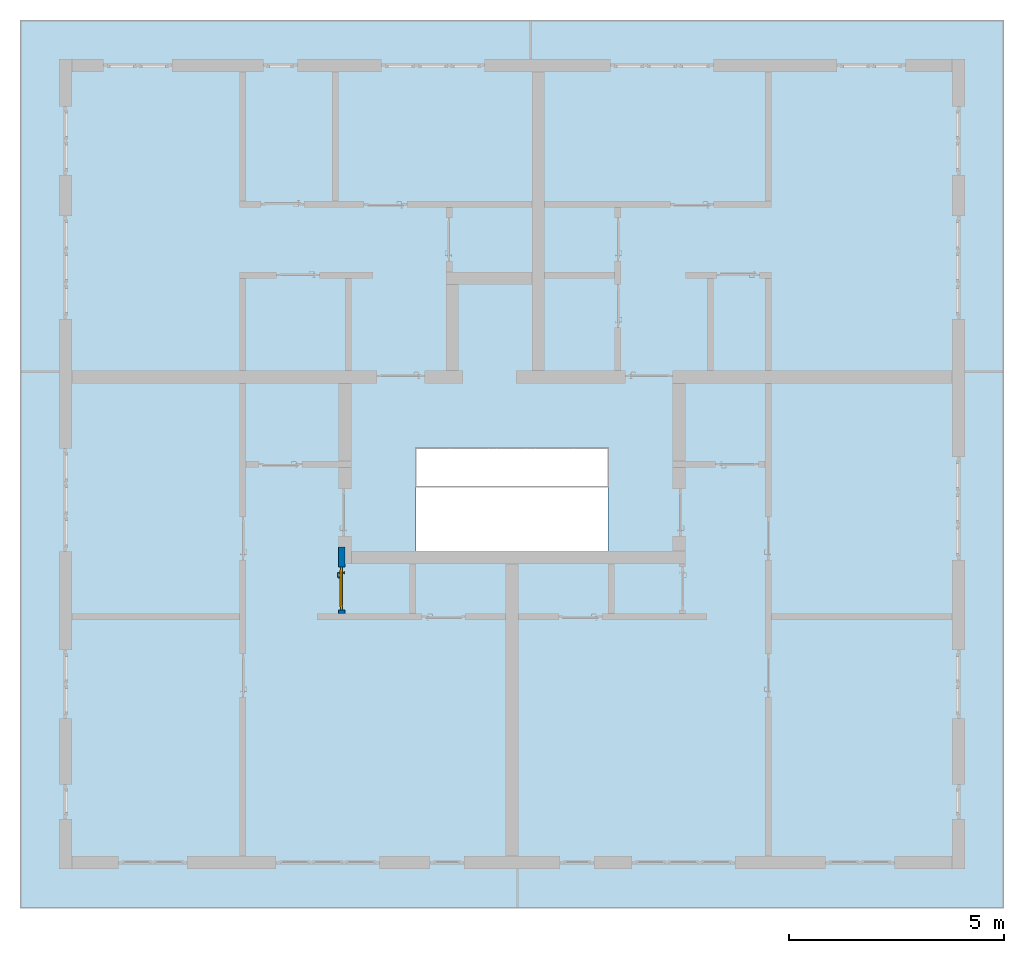
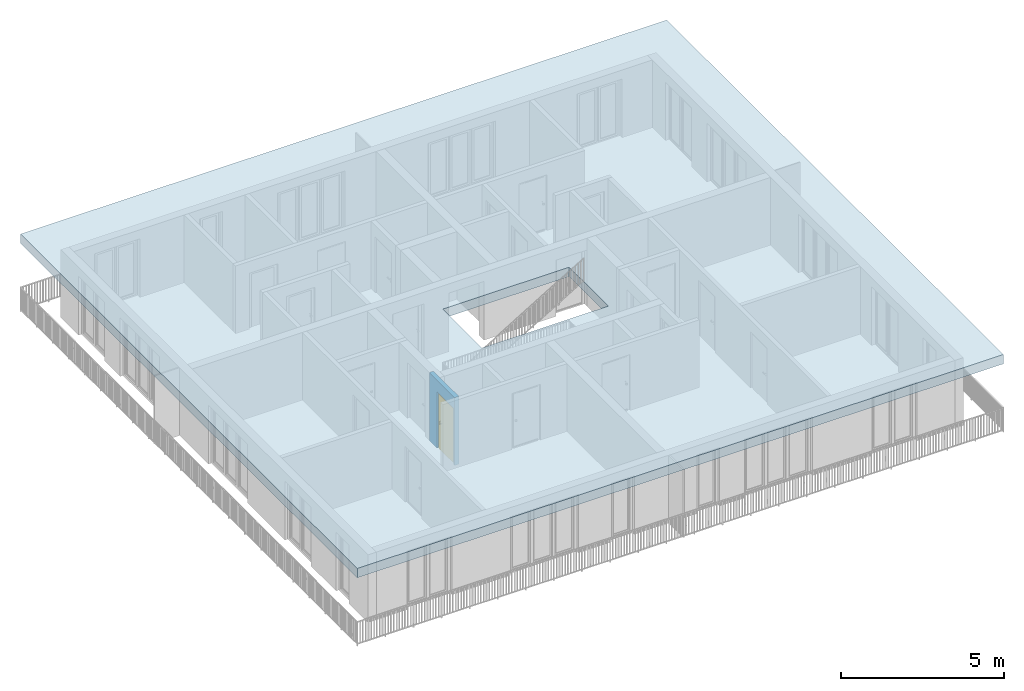
# One storey, part 1 of 54: 1 door, 1 slab, 1 wall, 1 opening.
"""IFC4 building model written with IfcOpenShell, lengths in metres."""

from ifc_helpers import new_model, entity, si_unit, converted_unit, derived_unit, direction, frame, origin_with_axes, place, context, subcontext, project, spatial, polygons, source, transform, mapped, material, type_object, element, fill, save


model = new_model("IFC4")

# Units and contexts
model_context = context("Model", 3, precision=1e-05, world=origin_with_axes(), true_north=direction((0.0, 1.0)))
body_context = subcontext(model_context, "Body", "Model", "MODEL_VIEW")
ifc_project = project(units=[si_unit("LENGTHUNIT", "METRE"), si_unit("AREAUNIT", "SQUARE_METRE"), si_unit("VOLUMEUNIT", "CUBIC_METRE"), converted_unit("PLANEANGLEUNIT", "DEGREE", entity("IfcPlaneAngleMeasure", 0.0174532925199), si_unit("PLANEANGLEUNIT", "RADIAN"), dimensions=[0, 0, 0, 0, 0, 0, 0]), converted_unit("TIMEUNIT", "Year", entity("IfcTimeMeasure", 31556926.0), si_unit("TIMEUNIT", "SECOND"), dimensions=[0, 0, 1, 0, 0, 0, 0]), si_unit("MASSUNIT", "GRAM", prefix="KILO"), si_unit("THERMODYNAMICTEMPERATUREUNIT", "DEGREE_CELSIUS"), si_unit("LUMINOUSINTENSITYUNIT", "LUMEN"), si_unit("ENERGYUNIT", "JOULE", prefix="MEGA"), derived_unit("THERMALCONDUCTANCEUNIT", [(si_unit("POWERUNIT", "WATT"), 1), (si_unit("LENGTHUNIT", "METRE"), -1), (si_unit("THERMODYNAMICTEMPERATUREUNIT", "KELVIN"), -1)]), derived_unit("SPECIFICHEATCAPACITYUNIT", [(si_unit("ENERGYUNIT", "JOULE"), 1), (si_unit("MASSUNIT", "GRAM", prefix="KILO"), -1), (si_unit("THERMODYNAMICTEMPERATUREUNIT", "KELVIN"), -1)]), derived_unit("MASSDENSITYUNIT", [(si_unit("MASSUNIT", "GRAM", prefix="KILO"), 1), (si_unit("VOLUMEUNIT", "CUBIC_METRE"), -1)])], contexts=[model_context])

# Site, building, storey, space
site_placement = place(None, origin_with_axes())
site = spatial("IfcSite", under=ifc_project, at=site_placement, CompositionType="ELEMENT")
building_placement = place(site_placement, origin_with_axes())
building = spatial("IfcBuilding", under=site, at=building_placement, CompositionType="ELEMENT")
storey_placement = place(building_placement, frame((0.0, 0.0, 6.29), z_axis=(0.0, 0.0, 1.0), x_axis=(1.0, 0.0, 0.0)))
storey = spatial("IfcBuildingStorey", under=building, at=storey_placement, Name="2. Geschoss", CompositionType="ELEMENT", Elevation=6.29)
space_placement = place(storey_placement, frame((-0.742199380397, 1.67118776896, 0.0), z_axis=(0.0, 0.0, 1.0), x_axis=(0.0, 1.0, 0.0)))
space = spatial("IfcSpace", under=storey, at=space_placement, CompositionType="ELEMENT", PredefinedType="INTERNAL")

# Slab
ifc_material = material()
slab_type = type_object("IfcSlabType", Name="350", PredefinedType="NOTDEFINED")
slab_placement = place(space_placement, frame((-12.5, 11.9, 2.89), z_axis=(0.0, 0.0, 1.0), x_axis=(0.0, -1.0, 0.0)))
element("IfcSlab", 1, at=slab_placement, inside=space, type_object=slab_type, material=ifc_material, Name="Decke-001", PredefinedType="NOTDEFINED", context=body_context, shape_type="Tessellation", body=[
    polygons([(0.0, 0.0, 0.0), (0.0, 0.0, -0.35), (22.88, 0.0, -0.35), (22.88, 0.0, 0.0), (0.0, 20.65, 0.0), (0.0, 20.65, -0.35), (22.88, 20.65, -0.35), (13.68, 8.3, -0.35), (13.68, 10.7, -0.35), (9.2, 10.7, -0.35), (9.2, 8.3, -0.35), (22.88, 20.65, 0.0), (9.2, 10.7, 0.0), (13.68, 10.7, 0.0), (13.68, 8.3, 0.0), (9.2, 8.3, 0.0)], [[[1, 2, 3, 4]], [[5, 6, 2, 1]], [[3, 2, 6, 7], [8, 9, 10, 11]], [[4, 3, 7, 12]], [[5, 1, 4, 12], [13, 14, 15, 16]], [[12, 7, 6, 5]], [[14, 9, 8, 15]], [[13, 10, 9, 14]], [[16, 11, 10, 13]], [[15, 8, 11, 16]]], closed=True),
])

# Wall, opening, door
wall_type = type_object("IfcWallType", Name="150", PredefinedType="NOTDEFINED")
wall_placement = place(storey_placement, frame((-5.2421993804, -4.12881223104, 0.0), z_axis=(0.0, 0.0, 1.0), x_axis=(0.0, 1.0, 0.0)))
wall = element("IfcWall", 2, at=wall_placement, inside=storey, type_object=wall_type, material=ifc_material, Name="Wand-002", PredefinedType="NOTDEFINED", context=body_context, shape_type="Tessellation", body=[
    polygons([(0.225, -0.15, 2.1), (0.225, 0.0, 2.1), (1.225, 0.0, 2.1), (1.225, -0.15, 2.1), (0.225, -0.1, 0.0), (0.225, 0.0, 0.0), (0.225, -0.15, 0.0), (0.15, 0.0, 0.0), (0.15, 0.0, 2.54), (1.7, 0.0, 2.54), (1.7, 0.0, 0.0), (1.225, 0.0, 0.0), (1.225, -0.1, 0.0), (1.225, -0.15, 0.0), (1.7, -0.15, 2.54), (0.15, -0.15, 2.54), (0.15, -0.15, 0.0), (1.7, -0.15, 0.0)], [[[1, 2, 3, 4]], [[5, 6, 2, 1, 7]], [[2, 6, 8, 9, 10, 11, 12, 3]], [[4, 3, 12, 13, 14]], [[15, 16, 17, 7, 1, 4, 14, 18]], [[6, 5, 7, 17, 8]], [[9, 8, 17, 16]], [[15, 10, 9, 16]], [[15, 18, 11, 10]], [[13, 12, 11, 18, 14]]], closed=True),
])
opening_placement = place(wall_placement, frame((0.725, 0.0, 0.0), z_axis=(0.0, 0.0, 1.0), x_axis=(1.0, 0.0, 0.0)))
opening = element("IfcOpeningElement", 3, at=opening_placement, cuts=wall, context=body_context, identifier="Reference", shape_type="Tessellation", body=[
    polygons([(0.5, -0.1, 0.0), (0.5, -0.1, 2.1), (0.5, -0.151, 2.1), (0.5, -0.151, 0.0), (0.5, 0.001, 0.0), (0.5, 0.001, 2.1), (-0.5, -0.1, 2.1), (-0.5, -0.151, 2.1), (-0.5, 0.001, 2.1), (-0.5, -0.151, 0.0), (-0.5, -0.1, 0.0), (-0.5, 0.001, 0.0)], [[[1, 2, 3, 4]], [[2, 1, 5, 6]], [[7, 8, 3, 2, 6, 9]], [[8, 10, 4, 3]], [[1, 4, 10, 11, 12, 5]], [[6, 5, 12, 9]], [[7, 11, 10, 8]], [[11, 7, 9, 12]]], closed=True),
])
door_type = type_object("IfcDoorType", Name="Eingang 01 1-Fl 26", OperationType="SINGLE_SWING_LEFT", PredefinedType="DOOR")
shared_shape = source(origin_with_axes(), body_context, "Body", "Tessellation", [
    polygons([(-0.5, -0.05, 0.0), (-0.5, -0.05, 2.1), (-0.5, -0.03, 2.1), (-0.5, -0.03, 0.0), (-0.4, -0.05, 0.0), (-0.4, -0.05, 2.0), (-0.1301, -0.05, 2.0), (-0.0001, -0.05, 2.0), (0.4, -0.05, 2.0), (0.4, -0.05, 0.0), (0.5, -0.05, 0.0), (0.5, -0.05, 2.1), (0.5, -0.03, 2.1), (0.5, -0.03, 0.0), (0.4, -0.03, 0.0), (0.4, -0.03, 2.0), (-0.0001, -0.03, 2.0), (-0.1301, -0.03, 2.0), (-0.4, -0.03, 2.0), (-0.4, -0.03, 0.0)], [[[1, 2, 3, 4]], [[1, 5, 6, 7, 8, 9, 10, 11, 12, 2]], [[2, 12, 13, 3]], [[4, 3, 13, 14, 15, 16, 17, 18, 19, 20]], [[5, 1, 4, 20]], [[6, 5, 20, 19]], [[7, 6, 19, 18]], [[8, 7, 18, 17]], [[9, 8, 17, 16]], [[10, 9, 16, 15]], [[11, 10, 15, 14]], [[12, 11, 14, 13]]], closed=True),
    polygons([(-0.5, -0.03, 0.0), (-0.5, -0.03, 2.1), (-0.5, 0.0, 2.1), (-0.5, 0.0, 0.0), (-0.43, -0.03, 0.0), (-0.43, -0.03, 2.03), (-0.1001, -0.03, 2.03), (-0.0301, -0.03, 2.03), (0.43, -0.03, 2.03), (0.43, -0.03, 0.0), (0.5, -0.03, 0.0), (0.5, -0.03, 2.1), (0.5, 0.0, 2.1), (0.5, 0.0, 0.0), (0.43, 0.0, 0.0), (0.43, 0.0, 2.03), (-0.0301, 0.0, 2.03), (-0.1001, 0.0, 2.03), (-0.43, 0.0, 2.03), (-0.43, 0.0, 0.0)], [[[1, 2, 3, 4]], [[1, 5, 6, 7, 8, 9, 10, 11, 12, 2]], [[2, 12, 13, 3]], [[4, 3, 13, 14, 15, 16, 17, 18, 19, 20]], [[5, 1, 4, 20]], [[6, 5, 20, 19]], [[7, 6, 19, 18]], [[8, 7, 18, 17]], [[9, 8, 17, 16]], [[10, 9, 16, 15]], [[11, 10, 15, 14]], [[12, 11, 14, 13]]], closed=True),
    polygons([(-0.43, 0.01, 0.0), (-0.43, 0.01, 2.03), (0.43, 0.01, 2.03), (0.43, 0.01, 0.0), (-0.43, -0.03, 0.0), (-0.43, -0.03, 2.03), (0.43, -0.03, 2.03), (0.43, -0.03, 0.0)], [[[1, 2, 3, 4]], [[1, 5, 6, 2]], [[2, 6, 7, 3]], [[3, 7, 8, 4]], [[4, 8, 5, 1]], [[8, 7, 6, 5]]], closed=True),
    polygons([(-0.395, -0.05, 0.0), (0.395, -0.05, 0.0), (0.395, -0.05, 0.05), (-0.395, -0.05, 0.05), (-0.395, -0.03, 0.0), (0.395, -0.03, 0.0), (0.395, -0.03, 0.07), (0.395, -0.035, 0.07), (-0.395, -0.035, 0.07), (-0.395, -0.03, 0.07)], [[[1, 2, 3, 4]], [[5, 6, 2, 1]], [[2, 6, 7, 8, 3]], [[4, 3, 8, 9]], [[1, 4, 9, 10, 5]], [[10, 7, 6, 5]], [[9, 8, 7, 10]]], closed=True),
    polygons([(0.3835, 0.02, 1.0733826859), (0.37, 0.02, 1.077), (0.37, 0.0199, 1.077), (0.3835, 0.0199, 1.0733826859), (0.393382685902, 0.02, 1.0635), (0.397, 0.02, 1.05), (0.393382685902, 0.02, 1.0365), (0.3835, 0.02, 1.0266173141), (0.37, 0.02, 1.023), (0.3565, 0.02, 1.0266173141), (0.346617314098, 0.02, 1.0365), (0.343, 0.02, 1.05), (0.346617314098, 0.02, 1.0635), (0.3565, 0.02, 1.0733826859), (0.3565, 0.0199, 1.0733826859), (0.37, 0.0101, 1.077), (0.3835, 0.0101, 1.0733826859), (0.393382685902, 0.0199, 1.0635), (0.397, 0.0199, 1.05), (0.393382685902, 0.0199, 1.0365), (0.3835, 0.0199, 1.0266173141), (0.37, 0.0199, 1.023), (0.3565, 0.0199, 1.0266173141), (0.346617314098, 0.0199, 1.0365), (0.343, 0.0199, 1.05), (0.346617314098, 0.0199, 1.0635), (0.3565, 0.0101, 1.0733826859), (0.37, 0.01, 1.077), (0.3835, 0.01, 1.0733826859), (0.393382685902, 0.0101, 1.0635), (0.397, 0.0101, 1.05), (0.393382685902, 0.0101, 1.0365), (0.3835, 0.0101, 1.0266173141), (0.37, 0.0101, 1.023), (0.3565, 0.0101, 1.0266173141), (0.346617314098, 0.0101, 1.0365), (0.343, 0.0101, 1.05), (0.346617314098, 0.0101, 1.0635), (0.3565, 0.01, 1.0733826859), (0.346617314098, 0.01, 1.0635), (0.343, 0.01, 1.05), (0.346617314098, 0.01, 1.0365), (0.3565, 0.01, 1.0266173141), (0.37, 0.01, 1.023), (0.3835, 0.01, 1.0266173141), (0.393382685902, 0.01, 1.0365), (0.397, 0.01, 1.05), (0.393382685902, 0.01, 1.0635)], [[[1, 2, 3, 4]], [[2, 1, 5, 6, 7, 8, 9, 10, 11, 12, 13, 14]], [[2, 14, 15, 3]], [[4, 3, 16, 17]], [[5, 1, 4, 18]], [[6, 5, 18, 19]], [[7, 6, 19, 20]], [[8, 7, 20, 21]], [[9, 8, 21, 22]], [[10, 9, 22, 23]], [[11, 10, 23, 24]], [[12, 11, 24, 25]], [[13, 12, 25, 26]], [[14, 13, 26, 15]], [[3, 15, 27, 16]], [[17, 16, 28, 29]], [[18, 4, 17, 30]], [[19, 18, 30, 31]], [[20, 19, 31, 32]], [[21, 20, 32, 33]], [[22, 21, 33, 34]], [[23, 22, 34, 35]], [[24, 23, 35, 36]], [[25, 24, 36, 37]], [[26, 25, 37, 38]], [[15, 26, 38, 27]], [[16, 27, 39, 28]], [[28, 39, 40, 41, 42, 43, 44, 45, 46, 47, 48, 29]], [[30, 17, 29, 48]], [[31, 30, 48, 47]], [[32, 31, 47, 46]], [[33, 32, 46, 45]], [[34, 33, 45, 44]], [[35, 34, 44, 43]], [[36, 35, 43, 42]], [[37, 36, 42, 41]], [[38, 37, 41, 40]], [[27, 38, 40, 39]]], closed=True),
    polygons([(0.362532169224, 0.019, 0.959692280177), (0.363279754556, 0.019, 0.961639806549), (0.35705, 0.019, 0.972430057958), (0.347569942042, 0.019, 0.96295), (0.365, 0.019, 0.952886751346), (0.365, 0.019, 0.9544), (0.362532169224, 0.02, 0.959692280177), (0.363279754556, 0.02, 0.961639806549), (0.364624817685, 0.02, 0.965143815798), (0.364624817685, 0.019, 0.965143815798), (0.37, 0.019, 0.967425445323), (0.37, 0.019, 0.9759), (0.357, 0.019, 0.972516660498), (0.347483339502, 0.019, 0.963), (0.365, 0.019, 0.95), (0.3441, 0.019, 0.95), (0.365, 0.019, 0.947113248654), (0.365, 0.019, 0.941339745962), (0.365, 0.019, 0.9375), (0.365, 0.02, 0.9375), (0.365, 0.02, 0.941339745962), (0.365, 0.02, 0.947113248654), (0.365, 0.02, 0.95), (0.365, 0.02, 0.952886751346), (0.365, 0.02, 0.9544), (0.346703916638, 0.02, 0.96345), (0.35655, 0.02, 0.973296083362), (0.37, 0.02, 0.9769), (0.37, 0.02, 0.967425445323), (0.375375182315, 0.019, 0.965143815798), (0.376720245444, 0.019, 0.961639806549), (0.38295, 0.019, 0.972430057958), (0.37, 0.019, 0.976), (0.357, 0.0189, 0.972516660498), (0.347483339502, 0.0189, 0.963), (0.344, 0.019, 0.95), (0.347569942042, 0.019, 0.93705), (0.35705, 0.019, 0.927569942042), (0.37, 0.019, 0.9241), (0.37, 0.019, 0.9325), (0.366464466094, 0.019, 0.933964466094), (0.366464466094, 0.02, 0.933964466094), (0.37, 0.02, 0.9231), (0.35655, 0.02, 0.926703916638), (0.37, 0.02, 0.9325), (0.346703916638, 0.02, 0.93655), (0.3431, 0.02, 0.95), (0.346617314098, 0.02, 0.9635), (0.3565, 0.02, 0.973382685902), (0.37, 0.02, 0.977), (0.375375182315, 0.02, 0.965143815798), (0.38345, 0.02, 0.973296083362), (0.376720245444, 0.02, 0.961639806549), (0.377467830776, 0.02, 0.959692280177), (0.377467830776, 0.019, 0.959692280177), (0.375, 0.019, 0.9544), (0.375, 0.019, 0.952886751346), (0.392430057958, 0.019, 0.96295), (0.383, 0.019, 0.972516660498), (0.37, 0.0189, 0.976), (0.357, 0.0101, 0.972516660498), (0.347483339502, 0.0101, 0.963), (0.344, 0.0189, 0.95), (0.347483339502, 0.019, 0.937), (0.357, 0.019, 0.927483339502), (0.37, 0.019, 0.924), (0.38295, 0.019, 0.927569942042), (0.375, 0.019, 0.941339745962), (0.375, 0.019, 0.9375), (0.373535533906, 0.019, 0.933964466094), (0.37, 0.02, 0.923), (0.3565, 0.02, 0.926617314098), (0.38345, 0.02, 0.926703916638), (0.373535533906, 0.02, 0.933964466094), (0.375, 0.02, 0.9375), (0.375, 0.02, 0.941339745962), (0.346617314098, 0.02, 0.9365), (0.343, 0.02, 0.95), (0.346617314098, 0.0199, 0.9635), (0.3565, 0.0199, 0.973382685902), (0.37, 0.0199, 0.977), (0.3835, 0.02, 0.973382685902), (0.393296083362, 0.02, 0.96345), (0.375, 0.02, 0.952886751346), (0.375, 0.02, 0.9544), (0.375, 0.02, 0.95), (0.375, 0.02, 0.947113248654), (0.375, 0.019, 0.947113248654), (0.375, 0.019, 0.95), (0.3959, 0.019, 0.95), (0.392516660498, 0.019, 0.963), (0.383, 0.0189, 0.972516660498), (0.37, 0.0101, 0.976), (0.357, 0.01, 0.972516660498), (0.347483339502, 0.01, 0.963), (0.344, 0.0101, 0.95), (0.347483339502, 0.0189, 0.937), (0.357, 0.0189, 0.927483339502), (0.37, 0.0189, 0.924), (0.383, 0.019, 0.927483339502), (0.392430057958, 0.019, 0.93705), (0.37, 0.0199, 0.923), (0.3565, 0.0199, 0.926617314098), (0.3835, 0.02, 0.926617314098), (0.393296083362, 0.02, 0.93655), (0.346617314098, 0.0199, 0.9365), (0.343, 0.0199, 0.95), (0.346617314098, 0.0101, 0.9635), (0.3565, 0.0101, 0.973382685902), (0.37, 0.0101, 0.977), (0.3835, 0.0199, 0.973382685902), (0.393382685902, 0.02, 0.9635), (0.3969, 0.02, 0.95), (0.396, 0.019, 0.95), (0.392516660498, 0.0189, 0.963), (0.383, 0.0101, 0.972516660498), (0.37, 0.01, 0.976), (0.35695, 0.01, 0.972603263039), (0.347396736961, 0.01, 0.96305), (0.344, 0.01, 0.95), (0.347483339502, 0.0101, 0.937), (0.357, 0.0101, 0.927483339502), (0.37, 0.0101, 0.924), (0.383, 0.0189, 0.927483339502), (0.392516660498, 0.019, 0.937), (0.37, 0.0101, 0.923), (0.3565, 0.0101, 0.926617314098), (0.3835, 0.0199, 0.926617314098), (0.393382685902, 0.02, 0.9365), (0.346617314098, 0.0101, 0.9365), (0.343, 0.0101, 0.95), (0.346617314098, 0.01, 0.9635), (0.3565, 0.01, 0.973382685902), (0.37, 0.01, 0.977), (0.3835, 0.0101, 0.973382685902), (0.393382685902, 0.0199, 0.9635), (0.397, 0.02, 0.95), (0.396, 0.0189, 0.95), (0.392516660498, 0.0101, 0.963), (0.383, 0.01, 0.972516660498), (0.37, 0.01, 0.9761), (0.35655, 0.01, 0.973296083362), (0.346703916638, 0.01, 0.96345), (0.3439, 0.01, 0.95), (0.347483339502, 0.01, 0.937), (0.357, 0.01, 0.927483339502), (0.37, 0.01, 0.924), (0.383, 0.0101, 0.927483339502), (0.392516660498, 0.0189, 0.937), (0.37, 0.01, 0.923), (0.3565, 0.01, 0.926617314098), (0.3835, 0.0101, 0.926617314098), (0.393382685902, 0.0199, 0.9365), (0.346617314098, 0.01, 0.9365), (0.343, 0.01, 0.95), (0.37, 0.01, 0.9769), (0.3835, 0.01, 0.973382685902), (0.393382685902, 0.0101, 0.9635), (0.397, 0.0199, 0.95), (0.396, 0.0101, 0.95), (0.392516660498, 0.01, 0.963), (0.38305, 0.01, 0.972603263039), (0.3431, 0.01, 0.95), (0.347396736961, 0.01, 0.93695), (0.35695, 0.01, 0.927396736961), (0.37, 0.01, 0.9239), (0.383, 0.01, 0.927483339502), (0.392516660498, 0.0101, 0.937), (0.37, 0.01, 0.9231), (0.35655, 0.01, 0.926703916638), (0.3835, 0.01, 0.926617314098), (0.393382685902, 0.0101, 0.9365), (0.346703916638, 0.01, 0.93655), (0.38345, 0.01, 0.973296083362), (0.393382685902, 0.01, 0.9635), (0.397, 0.0101, 0.95), (0.396, 0.01, 0.95), (0.392603263039, 0.01, 0.96305), (0.38305, 0.01, 0.927396736961), (0.392516660498, 0.01, 0.937), (0.38345, 0.01, 0.926703916638), (0.393382685902, 0.01, 0.9365), (0.393296083362, 0.01, 0.96345), (0.397, 0.01, 0.95), (0.3961, 0.01, 0.95), (0.392603263039, 0.01, 0.93695), (0.393296083362, 0.01, 0.93655), (0.3969, 0.01, 0.95)], [[[1, 2, 3, 4, 5, 6]], [[1, 7, 8, 9, 10, 2]], [[10, 11, 12, 3, 2]], [[4, 3, 13, 14]], [[15, 5, 4, 16]], [[6, 5, 15, 17, 18, 19, 20, 21, 22, 23, 24, 25]], [[6, 25, 7, 1]], [[7, 25, 24, 26, 27, 8]], [[9, 8, 27, 28, 29]], [[10, 9, 29, 11]], [[30, 31, 32, 12, 11]], [[3, 12, 33, 13]], [[14, 13, 34, 35]], [[16, 4, 14, 36]], [[17, 15, 16, 37]], [[18, 17, 37, 38]], [[38, 39, 40, 41, 19, 18]], [[19, 41, 42, 20]], [[43, 44, 21, 20, 42, 45]], [[22, 21, 44, 46]], [[23, 22, 46, 47]], [[24, 23, 47, 26]], [[48, 49, 27, 26]], [[49, 50, 28, 27]], [[51, 29, 28, 52, 53]], [[11, 29, 51, 30]], [[30, 51, 53, 54, 55, 31]], [[55, 56, 57, 58, 32, 31]], [[12, 32, 59, 33]], [[13, 33, 60, 34]], [[35, 34, 61, 62]], [[36, 14, 35, 63]], [[37, 16, 36, 64]], [[38, 37, 64, 65]], [[39, 38, 65, 66]], [[39, 67, 68, 69, 70, 40]], [[41, 40, 45, 42]], [[71, 72, 44, 43]], [[73, 43, 45, 74, 75, 76]], [[72, 77, 46, 44]], [[77, 78, 47, 46]], [[78, 48, 26, 47]], [[79, 80, 49, 48]], [[80, 81, 50, 49]], [[50, 82, 52, 28]], [[54, 53, 52, 83, 84, 85]], [[55, 54, 85, 56]], [[85, 84, 86, 87, 76, 75, 69, 68, 88, 89, 57, 56]], [[57, 89, 90, 58]], [[32, 58, 91, 59]], [[33, 59, 92, 60]], [[34, 60, 93, 61]], [[62, 61, 94, 95]], [[63, 35, 62, 96]], [[64, 36, 63, 97]], [[65, 64, 97, 98]], [[66, 65, 98, 99]], [[67, 39, 66, 100]], [[88, 68, 67, 101]], [[70, 69, 75, 74]], [[40, 70, 74, 45]], [[102, 103, 72, 71]], [[104, 71, 43, 73]], [[76, 87, 105, 73]], [[103, 106, 77, 72]], [[106, 107, 78, 77]], [[107, 79, 48, 78]], [[108, 109, 80, 79]], [[109, 110, 81, 80]], [[81, 111, 82, 50]], [[82, 112, 83, 52]], [[86, 84, 83, 113]], [[87, 86, 113, 105]], [[89, 88, 101, 90]], [[58, 90, 114, 91]], [[59, 91, 115, 92]], [[60, 92, 116, 93]], [[61, 93, 117, 94]], [[95, 94, 118, 119]], [[96, 62, 95, 120]], [[97, 63, 96, 121]], [[98, 97, 121, 122]], [[99, 98, 122, 123]], [[100, 66, 99, 124]], [[101, 67, 100, 125]], [[126, 127, 103, 102]], [[128, 102, 71, 104]], [[129, 104, 73, 105]], [[127, 130, 106, 103]], [[130, 131, 107, 106]], [[131, 108, 79, 107]], [[132, 133, 109, 108]], [[133, 134, 110, 109]], [[110, 135, 111, 81]], [[111, 136, 112, 82]], [[112, 137, 113, 83]], [[137, 129, 105, 113]], [[90, 101, 125, 114]], [[91, 114, 138, 115]], [[92, 115, 139, 116]], [[93, 116, 140, 117]], [[94, 117, 141, 118]], [[119, 118, 142, 143]], [[120, 95, 119, 144]], [[121, 96, 120, 145]], [[122, 121, 145, 146]], [[123, 122, 146, 147]], [[124, 99, 123, 148]], [[125, 100, 124, 149]], [[150, 151, 127, 126]], [[152, 126, 102, 128]], [[153, 128, 104, 129]], [[151, 154, 130, 127]], [[154, 155, 131, 130]], [[155, 132, 108, 131]], [[143, 142, 133, 132]], [[142, 156, 134, 133]], [[134, 157, 135, 110]], [[135, 158, 136, 111]], [[136, 159, 137, 112]], [[159, 153, 129, 137]], [[114, 125, 149, 138]], [[115, 138, 160, 139]], [[116, 139, 161, 140]], [[117, 140, 162, 141]], [[118, 141, 156, 142]], [[144, 119, 143, 163]], [[145, 120, 144, 164]], [[146, 145, 164, 165]], [[147, 146, 165, 166]], [[148, 123, 147, 167]], [[149, 124, 148, 168]], [[169, 170, 151, 150]], [[171, 150, 126, 152]], [[172, 152, 128, 153]], [[170, 173, 154, 151]], [[173, 163, 155, 154]], [[163, 143, 132, 155]], [[156, 174, 157, 134]], [[157, 175, 158, 135]], [[158, 176, 159, 136]], [[176, 172, 153, 159]], [[138, 149, 168, 160]], [[139, 160, 177, 161]], [[140, 161, 178, 162]], [[141, 162, 174, 156]], [[164, 144, 163, 173]], [[165, 164, 173, 170]], [[166, 165, 170, 169]], [[167, 147, 166, 179]], [[168, 148, 167, 180]], [[181, 169, 150, 171]], [[182, 171, 152, 172]], [[174, 183, 175, 157]], [[175, 184, 176, 158]], [[184, 182, 172, 176]], [[160, 168, 180, 177]], [[161, 177, 185, 178]], [[162, 178, 183, 174]], [[179, 166, 169, 181]], [[180, 167, 179, 186]], [[187, 181, 171, 182]], [[183, 188, 184, 175]], [[188, 187, 182, 184]], [[177, 180, 186, 185]], [[178, 185, 188, 183]], [[186, 179, 181, 187]], [[185, 186, 187, 188]]], closed=True),
    polygons([(0.38, 0.02, 1.05), (0.377071067812, 0.02, 1.04292893219), (0.377071067812, 0.050696439392, 1.04292893219), (0.38, 0.0509849140336, 1.05), (0.37, 0.02, 1.04), (0.37, 0.05, 1.04), (0.375518993221, 0.0584992452783, 1.04292893219), (0.378277987014, 0.0596420579258, 1.05), (0.377071067812, 0.02, 1.05707106781), (0.377071067812, 0.050696439392, 1.05707106781), (0.362928932188, 0.02, 1.04292893219), (0.362928932188, 0.049303560608, 1.04292893219), (0.368858192988, 0.0557402514855, 1.04), (0.370704557509, 0.0657045575088, 1.04292893219), (0.372816199938, 0.0678161999379, 1.05), (0.375518993221, 0.0584992452783, 1.05707106781), (0.37, 0.02, 1.06), (0.37, 0.05, 1.06), (0.36, 0.02, 1.05), (0.36, 0.0490150859664, 1.05), (0.362197392755, 0.0529812576926, 1.04292893219), (0.365606601718, 0.0606066017178, 1.04), (0.363499245278, 0.0705189932208, 1.04292893219), (0.364642057926, 0.0732779870137, 1.05), (0.370704557509, 0.0657045575088, 1.05707106781), (0.368858192988, 0.0557402514855, 1.06), (0.362928932188, 0.02, 1.05707106781), (0.362928932188, 0.049303560608, 1.05707106781), (0.359438398962, 0.0518384450452, 1.05), (0.360508645927, 0.0555086459268, 1.04292893219), (0.360740251485, 0.0638581929877, 1.04), (0.355696439392, 0.0720710678119, 1.04292893219), (0.355984914034, 0.075, 1.05), (0.363499245278, 0.0705189932208, 1.05707106781), (0.365606601718, 0.0606066017178, 1.06), (0.362197392755, 0.0529812576926, 1.05707106781), (0.358397003498, 0.0533970034977, 1.05), (0.357981257693, 0.0571973927545, 1.04292893219), (0.355, 0.065, 1.04), (0.274303560608, 0.0720710678119, 1.04292893219), (0.274015085966, 0.075, 1.05), (0.355696439392, 0.0720710678119, 1.05707106781), (0.360740251485, 0.0638581929877, 1.06), (0.360508645927, 0.0555086459268, 1.05707106781), (0.356838445045, 0.0544383989617, 1.05), (0.354303560608, 0.0579289321881, 1.04292893219), (0.275, 0.065, 1.04), (0.266500754722, 0.0705189932208, 1.04292893219), (0.265357942074, 0.0732779870137, 1.05), (0.274303560608, 0.0720710678119, 1.05707106781), (0.355, 0.065, 1.06), (0.357981257693, 0.0571973927545, 1.05707106781), (0.354015085966, 0.055, 1.05), (0.275696439392, 0.0579289321881, 1.04292893219), (0.269259748515, 0.0638581929877, 1.04), (0.259295442491, 0.0657045575088, 1.04292893219), (0.257183800062, 0.0678161999379, 1.05), (0.266500754722, 0.0705189932208, 1.05707106781), (0.275, 0.065, 1.06), (0.354303560608, 0.0579289321881, 1.05707106781), (0.275984914034, 0.055, 1.05), (0.272018742307, 0.0571973927545, 1.04292893219), (0.264393398282, 0.0606066017178, 1.04), (0.254481006779, 0.0584992452783, 1.04292893219), (0.251722012986, 0.0596420579258, 1.05), (0.259295442491, 0.0657045575088, 1.05707106781), (0.269259748515, 0.0638581929877, 1.06), (0.275696439392, 0.0579289321881, 1.05707106781), (0.273161554955, 0.0544383989617, 1.05), (0.269491354073, 0.0555086459268, 1.04292893219), (0.261141807012, 0.0557402514855, 1.04), (0.252928932188, 0.050696439392, 1.04292893219), (0.25, 0.0509849140336, 1.05), (0.254481006779, 0.0584992452783, 1.05707106781), (0.264393398282, 0.0606066017178, 1.06), (0.272018742307, 0.0571973927545, 1.05707106781), (0.271602996502, 0.0533970034977, 1.05), (0.267802607245, 0.0529812576926, 1.04292893219), (0.26, 0.05, 1.04), (0.252928932188, 0.02, 1.04292893219), (0.25, 0.02, 1.05), (0.252928932188, 0.050696439392, 1.05707106781), (0.261141807012, 0.0557402514855, 1.06), (0.269491354073, 0.0555086459268, 1.05707106781), (0.270561601038, 0.0518384450452, 1.05), (0.267071067812, 0.049303560608, 1.04292893219), (0.26, 0.02, 1.04), (0.267071067812, 0.02, 1.04292893219), (0.27, 0.02, 1.05), (0.267071067812, 0.02, 1.05707106781), (0.26, 0.02, 1.06), (0.252928932188, 0.02, 1.05707106781), (0.26, 0.05, 1.06), (0.267802607245, 0.0529812576926, 1.05707106781), (0.27, 0.0490150859664, 1.05), (0.267071067812, 0.049303560608, 1.05707106781)], [[[1, 2, 3, 4]], [[2, 5, 6, 3]], [[4, 3, 7, 8]], [[9, 1, 4, 10]], [[5, 11, 12, 6]], [[3, 6, 13, 7]], [[8, 7, 14, 15]], [[10, 4, 8, 16]], [[17, 9, 10, 18]], [[11, 19, 20, 12]], [[6, 12, 21, 13]], [[7, 13, 22, 14]], [[15, 14, 23, 24]], [[16, 8, 15, 25]], [[18, 10, 16, 26]], [[27, 17, 18, 28]], [[19, 27, 28, 20]], [[12, 20, 29, 21]], [[13, 21, 30, 22]], [[14, 22, 31, 23]], [[24, 23, 32, 33]], [[25, 15, 24, 34]], [[26, 16, 25, 35]], [[28, 18, 26, 36]], [[20, 28, 36, 29]], [[21, 29, 37, 30]], [[22, 30, 38, 31]], [[23, 31, 39, 32]], [[33, 32, 40, 41]], [[34, 24, 33, 42]], [[35, 25, 34, 43]], [[36, 26, 35, 44]], [[29, 36, 44, 37]], [[30, 37, 45, 38]], [[31, 38, 46, 39]], [[32, 39, 47, 40]], [[41, 40, 48, 49]], [[42, 33, 41, 50]], [[43, 34, 42, 51]], [[44, 35, 43, 52]], [[37, 44, 52, 45]], [[38, 45, 53, 46]], [[39, 46, 54, 47]], [[40, 47, 55, 48]], [[49, 48, 56, 57]], [[50, 41, 49, 58]], [[51, 42, 50, 59]], [[52, 43, 51, 60]], [[45, 52, 60, 53]], [[46, 53, 61, 54]], [[47, 54, 62, 55]], [[48, 55, 63, 56]], [[57, 56, 64, 65]], [[58, 49, 57, 66]], [[59, 50, 58, 67]], [[60, 51, 59, 68]], [[53, 60, 68, 61]], [[54, 61, 69, 62]], [[55, 62, 70, 63]], [[56, 63, 71, 64]], [[65, 64, 72, 73]], [[66, 57, 65, 74]], [[67, 58, 66, 75]], [[68, 59, 67, 76]], [[61, 68, 76, 69]], [[62, 69, 77, 70]], [[63, 70, 78, 71]], [[64, 71, 79, 72]], [[73, 72, 80, 81]], [[74, 65, 73, 82]], [[75, 66, 74, 83]], [[76, 67, 75, 84]], [[69, 76, 84, 77]], [[70, 77, 85, 78]], [[71, 78, 86, 79]], [[72, 79, 87, 80]], [[81, 80, 87, 88, 89, 90, 91, 92]], [[82, 73, 81, 92]], [[83, 74, 82, 93]], [[84, 75, 83, 94]], [[77, 84, 94, 85]], [[78, 85, 95, 86]], [[79, 86, 88, 87]], [[86, 95, 89, 88]], [[95, 96, 90, 89]], [[96, 93, 91, 90]], [[93, 82, 92, 91]], [[94, 83, 93, 96]], [[85, 94, 96, 95]]], closed=False),
    polygons([(0.364696699141, -0.035, 1.04469669914), (0.3625, -0.035, 1.05), (0.364696699141, -0.035, 1.05530330086), (0.37, -0.035, 1.0575), (0.375303300859, -0.035, 1.05530330086), (0.3775, -0.035, 1.05), (0.375303300859, -0.035, 1.04469669914), (0.37, -0.035, 1.0425), (0.364696699141, -0.075, 1.04469669914), (0.3625, -0.075, 1.05), (0.364696699141, -0.075, 1.05530330086), (0.37, -0.075, 1.0575), (0.375303300859, -0.075, 1.05530330086), (0.3775, -0.075, 1.05), (0.375303300859, -0.075, 1.04469669914), (0.37, -0.075, 1.0425)], [[[1, 2, 3, 4, 5, 6, 7, 8]], [[1, 9, 10, 2]], [[2, 10, 11, 3]], [[3, 11, 12, 4]], [[4, 12, 13, 5]], [[5, 13, 14, 6]], [[6, 14, 15, 7]], [[7, 15, 16, 8]], [[8, 16, 9, 1]], [[9, 16, 15, 14, 13, 12, 11, 10]]], closed=True),
    polygons([(0.395, -0.03, 0.975), (0.395, -0.035, 0.975), (0.393096988313, -0.035, 0.965432914191), (0.393096988313, -0.03, 0.965432914191), (0.395, -0.03, 1.1), (0.395, -0.035, 1.1), (0.393096988313, -0.035, 1.10956708581), (0.38767766953, -0.035, 1.11767766953), (0.379567085809, -0.035, 1.12309698831), (0.37, -0.035, 1.125), (0.360432914191, -0.035, 1.12309698831), (0.35232233047, -0.035, 1.11767766953), (0.346903011687, -0.035, 1.10956708581), (0.345, -0.035, 1.1), (0.345, -0.035, 0.975), (0.346903011687, -0.035, 0.965432914191), (0.35232233047, -0.035, 0.95732233047), (0.360432914191, -0.035, 0.951903011687), (0.37, -0.035, 0.95), (0.379567085809, -0.035, 0.951903011687), (0.38767766953, -0.035, 0.95732233047), (0.38767766953, -0.03, 0.95732233047), (0.379567085809, -0.03, 0.951903011687), (0.37, -0.03, 0.95), (0.360432914191, -0.03, 0.951903011687), (0.35232233047, -0.03, 0.95732233047), (0.346903011687, -0.03, 0.965432914191), (0.345, -0.03, 0.975), (0.345, -0.03, 1.1), (0.346903011687, -0.03, 1.10956708581), (0.35232233047, -0.03, 1.11767766953), (0.360432914191, -0.03, 1.12309698831), (0.37, -0.03, 1.125), (0.379567085809, -0.03, 1.12309698831), (0.38767766953, -0.03, 1.11767766953), (0.393096988313, -0.03, 1.10956708581)], [[[1, 2, 3, 4]], [[5, 6, 2, 1]], [[2, 6, 7, 8, 9, 10, 11, 12, 13, 14, 15, 16, 17, 18, 19, 20, 21, 3]], [[4, 3, 21, 22]], [[1, 4, 22, 23, 24, 25, 26, 27, 28, 29, 30, 31, 32, 33, 34, 35, 36, 5]], [[36, 7, 6, 5]], [[35, 8, 7, 36]], [[34, 9, 8, 35]], [[33, 10, 9, 34]], [[32, 11, 10, 33]], [[31, 12, 11, 32]], [[30, 13, 12, 31]], [[29, 14, 13, 30]], [[28, 15, 14, 29]], [[27, 16, 15, 28]], [[26, 17, 16, 27]], [[25, 18, 17, 26]], [[24, 19, 18, 25]], [[23, 20, 19, 24]], [[22, 21, 20, 23]]], closed=True),
    polygons([(0.39, -0.075, 1.08), (0.39, -0.09, 1.08), (0.395, -0.09, 1.07866025404), (0.395, -0.075, 1.07866025404), (0.35, -0.075, 1.08), (0.35, -0.09, 1.08), (0.345, -0.09, 1.07866025404), (0.341339745962, -0.09, 1.075), (0.34, -0.09, 1.07), (0.34, -0.09, 1.03), (0.341339745962, -0.09, 1.025), (0.345, -0.09, 1.02133974596), (0.35, -0.09, 1.02), (0.39, -0.09, 1.02), (0.395, -0.09, 1.02133974596), (0.398660254038, -0.09, 1.025), (0.4, -0.09, 1.03), (0.4, -0.09, 1.07), (0.398660254038, -0.09, 1.075), (0.398660254038, -0.075, 1.075), (0.4, -0.075, 1.07), (0.4, -0.075, 1.03), (0.398660254038, -0.075, 1.025), (0.395, -0.075, 1.02133974596), (0.39, -0.075, 1.02), (0.35, -0.075, 1.02), (0.345, -0.075, 1.02133974596), (0.341339745962, -0.075, 1.025), (0.34, -0.075, 1.03), (0.34, -0.075, 1.07), (0.341339745962, -0.075, 1.075), (0.345, -0.075, 1.07866025404)], [[[1, 2, 3, 4]], [[5, 6, 2, 1]], [[2, 6, 7, 8, 9, 10, 11, 12, 13, 14, 15, 16, 17, 18, 19, 3]], [[4, 3, 19, 20]], [[1, 4, 20, 21, 22, 23, 24, 25, 26, 27, 28, 29, 30, 31, 32, 5]], [[32, 7, 6, 5]], [[31, 8, 7, 32]], [[30, 9, 8, 31]], [[29, 10, 9, 30]], [[28, 11, 10, 29]], [[27, 12, 11, 28]], [[26, 13, 12, 27]], [[25, 14, 13, 26]], [[24, 15, 14, 25]], [[23, 16, 15, 24]], [[22, 17, 16, 23]], [[21, 18, 17, 22]], [[20, 19, 18, 21]]], closed=True),
])
door_placement = place(opening_placement, frame((-0.4, 0.0, 0.0), z_axis=(0.0, 0.0, 1.0), x_axis=(1.0, 0.0, 0.0)))
door = element("IfcDoor", 4, at=door_placement, inside=storey, type_object=door_type, OverallHeight=2.1, OverallWidth=1.0, PredefinedType="DOOR", context=body_context, shape_type="MappedRepresentation", body=[
    mapped(shared_shape, transform((0.4, -0.05, 0.0))),
])
fill(opening, door)

save(model, "model.ifc")
